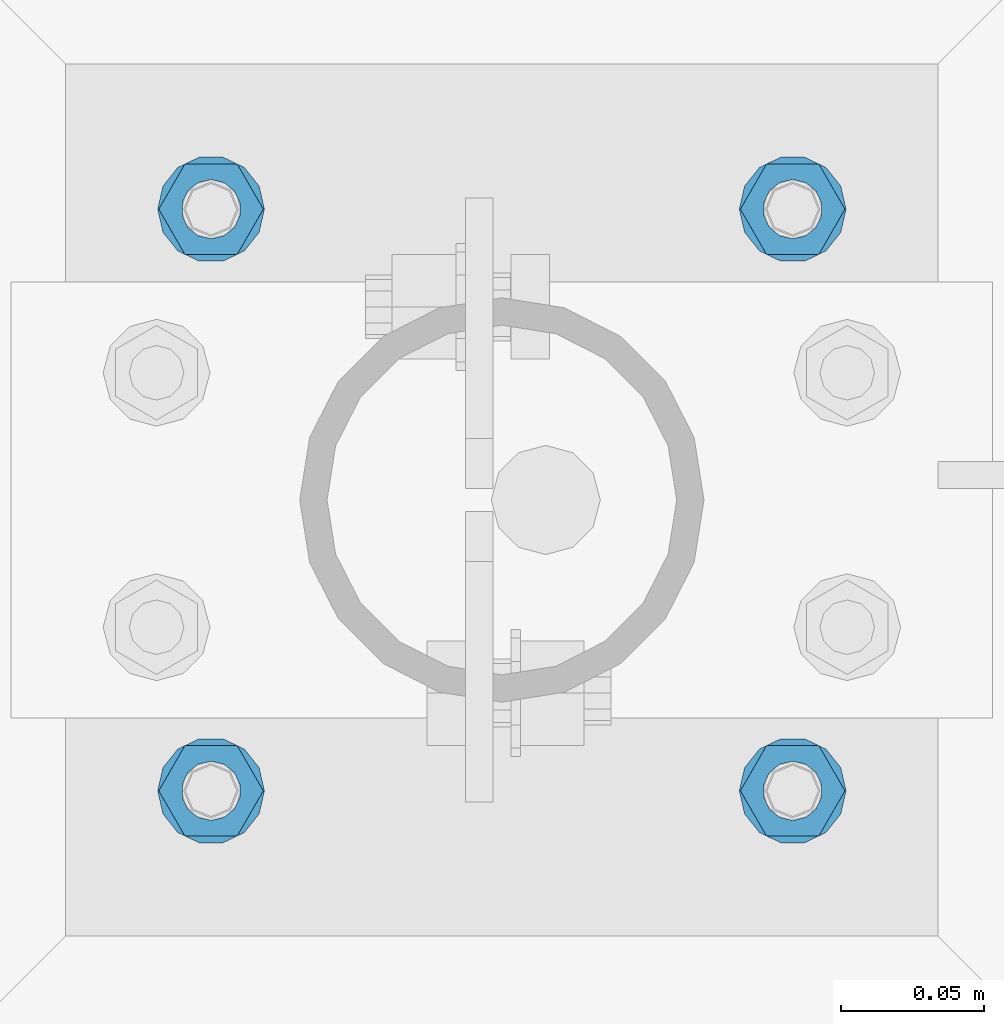
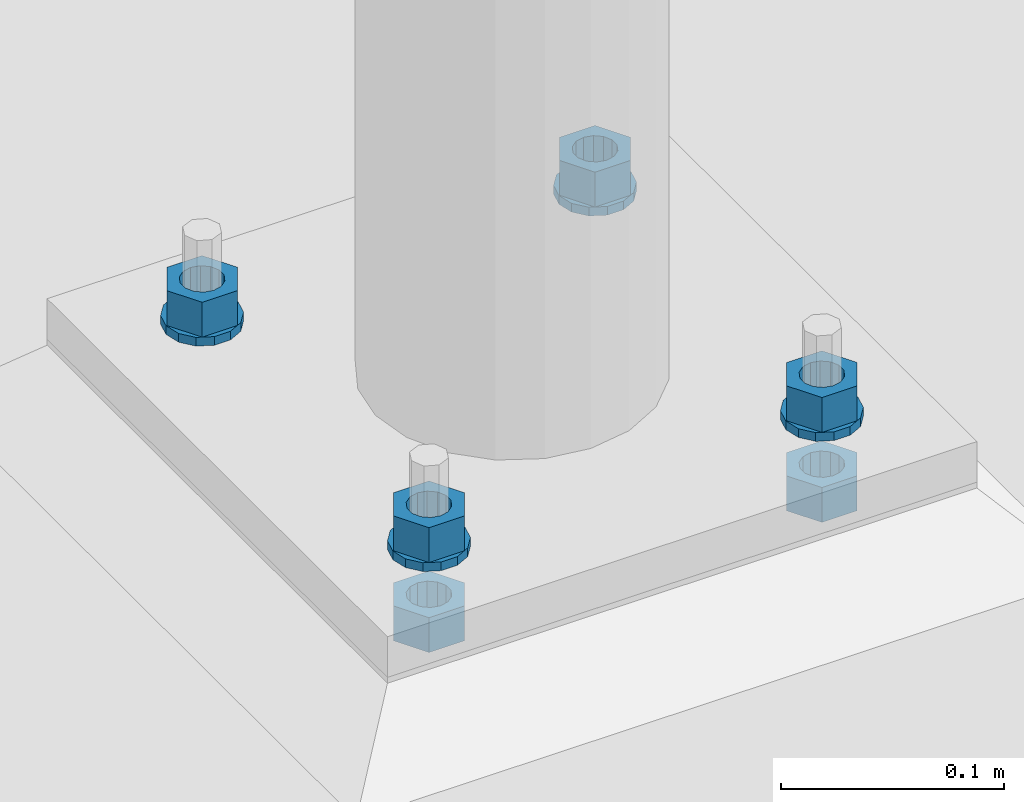
# One storey, part 582 of 975: 10 beams.
"""IFC2X3 building model written with IfcOpenShell, lengths in millimetres."""

from ifc_helpers import new_model, si_unit, frame, origin_with_axes, place, context, subcontext, project, spatial, faceted_brep, material, type_object, element, save


model = new_model("IFC2X3")

# Units and contexts
model_context = context("Model", 3, precision=1e-05, world=origin_with_axes())
body_context = subcontext(model_context, "Body", "Model", "MODEL_VIEW")
ifc_project = project(units=[si_unit("LENGTHUNIT", "METRE", prefix="MILLI"), si_unit("AREAUNIT", "SQUARE_METRE"), si_unit("VOLUMEUNIT", "CUBIC_METRE"), si_unit("MASSUNIT", "GRAM", prefix="KILO"), si_unit("TIMEUNIT", "SECOND"), si_unit("PLANEANGLEUNIT", "RADIAN"), si_unit("SOLIDANGLEUNIT", "STERADIAN"), si_unit("THERMODYNAMICTEMPERATUREUNIT", "DEGREE_CELSIUS"), si_unit("LUMINOUSINTENSITYUNIT", "LUMEN")], contexts=[model_context])

# Site, building, storey
site_placement = place(None, origin_with_axes())
site = spatial("IfcSite", under=ifc_project, at=site_placement, CompositionType="ELEMENT")
building_placement = place(site_placement, origin_with_axes())
building = spatial("IfcBuilding", under=site, at=building_placement, Name="Undefined", CompositionType="ELEMENT")
storey_placement = place(building_placement, origin_with_axes())
storey = spatial("IfcBuildingStorey", under=building, at=storey_placement, Name="Undefined", CompositionType="ELEMENT", Elevation=0.0)

# Beams
ifc_material = material(Name="STEEL/A36")
beam_type_1 = type_object("IfcBeamType", Name="3/4_WASHER", PredefinedType="NOTDEFINED")
beam_1_placement = place(storey_placement, frame((13385.8000015259, 13290.5500030518, -236.537499999998), z_axis=(0.0, -1.0, 0.0), x_axis=(0.0, 0.0, -1.0)))
element("IfcBeam", 1, at=beam_1_placement, inside=storey, type_object=beam_type_1, material=ifc_material, Name="WASHER", ObjectType="3/4_WASHER", context=body_context, shape_type="Brep", body=[
    faceted_brep([(0.0, -18.6499996185303, 0.0), (0.0, -16.8030690426876, -8.09193156902904), (4.76250000000073, -16.8030690426876, -8.09193156902904), (4.76250000000073, -18.6499996185303, 0.0), (0.0, -11.6280845668225, -14.5811568497838), (4.76250000000073, -11.6280845668225, -14.5811568497838), (0.0, -4.15001533340001, -18.1824051902857), (4.76250000000073, -4.15001533340001, -18.1824051902857), (0.0, 4.15001533340001, -18.1824051902857), (4.76250000000073, 4.15001533340001, -18.1824051902857), (0.0, 11.6280845668234, -14.5811568497838), (4.76250000000073, 11.6280845668234, -14.5811568497838), (0.0, 16.8030690426876, -8.09193156902904), (4.76250000000073, 16.8030690426876, -8.09193156902904), (0.0, 18.6499996185303, 0.0), (4.76250000000073, 18.6499996185303, 0.0), (0.0, 16.8030690426876, 8.09193156902904), (4.76250000000073, 16.8030690426876, 8.09193156902904), (0.0, 11.6280845668225, 14.5811568497838), (4.76250000000073, 11.6280845668225, 14.5811568497838), (0.0, 4.15001533340001, 18.1824051902857), (4.76250000000073, 4.15001533340001, 18.1824051902857), (0.0, -4.15001533340001, 18.1824051902857), (4.76250000000073, -4.15001533340001, 18.1824051902857), (0.0, -11.6280845668234, 14.5811568497838), (4.76250000000073, -11.6280845668234, 14.5811568497838), (0.0, -16.8030690426876, 8.09193156902904), (4.76250000000073, -16.8030690426876, 8.09193156902904), (0.0, 0.0, 10.3199996948242), (0.0, 4.47768005528269, 9.29799844179911), (4.76250000000073, 4.47768005528269, 9.29799844179911), (4.76250000000073, 0.0, 10.3199996948242), (0.0, 8.06850066047446, 6.43441456490817), (4.76250000000073, 8.06850066047446, 6.43441456490817), (0.0, 10.0612557561917, 2.29641597052117), (4.76250000000073, 10.0612557561917, 2.29641597052117), (0.0, 10.0612557561917, -2.29641597052117), (4.76250000000073, 10.0612557561917, -2.29641597052117), (0.0, 8.06850066047446, -6.43441456490814), (4.76250000000073, 8.06850066047446, -6.43441456490814), (0.0, 4.47768005528269, -9.29799844179908), (4.76250000000073, 4.47768005528269, -9.29799844179908), (0.0, 0.0, -10.3199996948242), (4.76250000000073, 0.0, -10.3199996948242), (0.0, -4.47768005528269, -9.29799844179911), (4.76250000000073, -4.47768005528269, -9.29799844179911), (0.0, -8.06850066047446, -6.43441456490817), (4.76250000000073, -8.06850066047446, -6.43441456490817), (0.0, -10.0612557561917, -2.29641597052117), (4.76250000000073, -10.0612557561917, -2.29641597052117), (0.0, -10.0612557561917, 2.29641597052117), (4.76250000000073, -10.0612557561917, 2.29641597052117), (0.0, -8.06850066047446, 6.43441456490814), (4.76250000000073, -8.06850066047446, 6.43441456490814), (0.0, -4.47768005528269, 9.29799844179908), (4.76250000000073, -4.47768005528269, 9.29799844179908)], [[[0, 1, 2, 3]], [[1, 4, 5, 2]], [[4, 6, 7, 5]], [[6, 8, 9, 7]], [[8, 10, 11, 9]], [[10, 12, 13, 11]], [[12, 14, 15, 13]], [[14, 16, 17, 15]], [[16, 18, 19, 17]], [[18, 20, 21, 19]], [[20, 22, 23, 21]], [[22, 24, 25, 23]], [[24, 26, 27, 25]], [[26, 0, 3, 27]], [[28, 29, 30, 31]], [[29, 32, 33, 30]], [[32, 34, 35, 33]], [[34, 36, 37, 35]], [[36, 38, 39, 37]], [[38, 40, 41, 39]], [[40, 42, 43, 41]], [[42, 44, 45, 43]], [[44, 46, 47, 45]], [[46, 48, 49, 47]], [[48, 50, 51, 49]], [[50, 52, 53, 51]], [[52, 54, 55, 53]], [[54, 28, 31, 55]], [[5, 7, 9, 11, 13, 15, 17, 19, 21, 23, 25, 27, 3, 2], [33, 35, 37, 39, 41, 43, 45, 47, 49, 51, 53, 55, 31, 30]], [[26, 24, 22, 20, 18, 16, 14, 12, 10, 8, 6, 4, 1, 0], [54, 52, 50, 48, 46, 44, 42, 40, 38, 36, 34, 32, 29, 28]]]),
])
beam_2_placement = place(storey_placement, frame((13588.9999984741, 13290.5500030518, -236.537499999998), z_axis=(0.0, -1.0, 0.0), x_axis=(0.0, 0.0, -1.0)))
element("IfcBeam", 2, at=beam_2_placement, inside=storey, type_object=beam_type_1, material=ifc_material, Name="WASHER", ObjectType="3/4_WASHER", context=body_context, shape_type="Brep", body=[
    faceted_brep([(0.0, -18.6499996185303, 0.0), (0.0, -16.8030690426876, -8.09193156902904), (4.76250000000073, -16.8030690426876, -8.09193156902904), (4.76250000000073, -18.6499996185303, 0.0), (0.0, -11.6280845668225, -14.5811568497838), (4.76250000000073, -11.6280845668225, -14.5811568497838), (0.0, -4.15001533340001, -18.1824051902857), (4.76250000000073, -4.15001533340001, -18.1824051902857), (0.0, 4.15001533340001, -18.1824051902857), (4.76250000000073, 4.15001533340001, -18.1824051902857), (0.0, 11.6280845668234, -14.5811568497838), (4.76250000000073, 11.6280845668234, -14.5811568497838), (0.0, 16.8030690426876, -8.09193156902904), (4.76250000000073, 16.8030690426876, -8.09193156902904), (0.0, 18.6499996185303, 0.0), (4.76250000000073, 18.6499996185303, 0.0), (0.0, 16.8030690426876, 8.09193156902904), (4.76250000000073, 16.8030690426876, 8.09193156902904), (0.0, 11.6280845668225, 14.5811568497838), (4.76250000000073, 11.6280845668225, 14.5811568497838), (0.0, 4.15001533340001, 18.1824051902857), (4.76250000000073, 4.15001533340001, 18.1824051902857), (0.0, -4.15001533340001, 18.1824051902857), (4.76250000000073, -4.15001533340001, 18.1824051902857), (0.0, -11.6280845668234, 14.5811568497838), (4.76250000000073, -11.6280845668234, 14.5811568497838), (0.0, -16.8030690426876, 8.09193156902904), (4.76250000000073, -16.8030690426876, 8.09193156902904), (0.0, 0.0, 10.3199996948242), (0.0, 4.47768005528269, 9.29799844179911), (4.76250000000073, 4.47768005528269, 9.29799844179911), (4.76250000000073, 0.0, 10.3199996948242), (0.0, 8.06850066047446, 6.43441456490817), (4.76250000000073, 8.06850066047446, 6.43441456490817), (0.0, 10.0612557561917, 2.29641597052117), (4.76250000000073, 10.0612557561917, 2.29641597052117), (0.0, 10.0612557561917, -2.29641597052117), (4.76250000000073, 10.0612557561917, -2.29641597052117), (0.0, 8.06850066047446, -6.43441456490814), (4.76250000000073, 8.06850066047446, -6.43441456490814), (0.0, 4.47768005528269, -9.29799844179908), (4.76250000000073, 4.47768005528269, -9.29799844179908), (0.0, 0.0, -10.3199996948242), (4.76250000000073, 0.0, -10.3199996948242), (0.0, -4.47768005528269, -9.29799844179911), (4.76250000000073, -4.47768005528269, -9.29799844179911), (0.0, -8.06850066047446, -6.43441456490817), (4.76250000000073, -8.06850066047446, -6.43441456490817), (0.0, -10.0612557561917, -2.29641597052117), (4.76250000000073, -10.0612557561917, -2.29641597052117), (0.0, -10.0612557561917, 2.29641597052117), (4.76250000000073, -10.0612557561917, 2.29641597052117), (0.0, -8.06850066047446, 6.43441456490814), (4.76250000000073, -8.06850066047446, 6.43441456490814), (0.0, -4.47768005528269, 9.29799844179908), (4.76250000000073, -4.47768005528269, 9.29799844179908)], [[[0, 1, 2, 3]], [[1, 4, 5, 2]], [[4, 6, 7, 5]], [[6, 8, 9, 7]], [[8, 10, 11, 9]], [[10, 12, 13, 11]], [[12, 14, 15, 13]], [[14, 16, 17, 15]], [[16, 18, 19, 17]], [[18, 20, 21, 19]], [[20, 22, 23, 21]], [[22, 24, 25, 23]], [[24, 26, 27, 25]], [[26, 0, 3, 27]], [[28, 29, 30, 31]], [[29, 32, 33, 30]], [[32, 34, 35, 33]], [[34, 36, 37, 35]], [[36, 38, 39, 37]], [[38, 40, 41, 39]], [[40, 42, 43, 41]], [[42, 44, 45, 43]], [[44, 46, 47, 45]], [[46, 48, 49, 47]], [[48, 50, 51, 49]], [[50, 52, 53, 51]], [[52, 54, 55, 53]], [[54, 28, 31, 55]], [[5, 7, 9, 11, 13, 15, 17, 19, 21, 23, 25, 27, 3, 2], [33, 35, 37, 39, 41, 43, 45, 47, 49, 51, 53, 55, 31, 30]], [[26, 24, 22, 20, 18, 16, 14, 12, 10, 8, 6, 4, 1, 0], [54, 52, 50, 48, 46, 44, 42, 40, 38, 36, 34, 32, 29, 28]]]),
])
beam_3_placement = place(storey_placement, frame((13385.8000015259, 13493.75, -236.537499999998), z_axis=(0.0, -1.0, 0.0), x_axis=(0.0, 0.0, -1.0)))
element("IfcBeam", 3, at=beam_3_placement, inside=storey, type_object=beam_type_1, material=ifc_material, Name="WASHER", ObjectType="3/4_WASHER", context=body_context, shape_type="Brep", body=[
    faceted_brep([(0.0, -18.6499996185303, 0.0), (0.0, -16.8030690426876, -8.09193156902904), (4.76250000000073, -16.8030690426876, -8.09193156902904), (4.76250000000073, -18.6499996185303, 0.0), (0.0, -11.6280845668225, -14.5811568497838), (4.76250000000073, -11.6280845668225, -14.5811568497838), (0.0, -4.15001533340001, -18.1824051902857), (4.76250000000073, -4.15001533340001, -18.1824051902857), (0.0, 4.15001533340001, -18.1824051902857), (4.76250000000073, 4.15001533340001, -18.1824051902857), (0.0, 11.6280845668234, -14.5811568497838), (4.76250000000073, 11.6280845668234, -14.5811568497838), (0.0, 16.8030690426876, -8.09193156902904), (4.76250000000073, 16.8030690426876, -8.09193156902904), (0.0, 18.6499996185303, 0.0), (4.76250000000073, 18.6499996185303, 0.0), (0.0, 16.8030690426876, 8.09193156902904), (4.76250000000073, 16.8030690426876, 8.09193156902904), (0.0, 11.6280845668225, 14.5811568497838), (4.76250000000073, 11.6280845668225, 14.5811568497838), (0.0, 4.15001533340001, 18.1824051902857), (4.76250000000073, 4.15001533340001, 18.1824051902857), (0.0, -4.15001533340001, 18.1824051902857), (4.76250000000073, -4.15001533340001, 18.1824051902857), (0.0, -11.6280845668234, 14.5811568497838), (4.76250000000073, -11.6280845668234, 14.5811568497838), (0.0, -16.8030690426876, 8.09193156902904), (4.76250000000073, -16.8030690426876, 8.09193156902904), (0.0, 0.0, 10.3199996948242), (0.0, 4.47768005528269, 9.29799844179911), (4.76250000000073, 4.47768005528269, 9.29799844179911), (4.76250000000073, 0.0, 10.3199996948242), (0.0, 8.06850066047446, 6.43441456490817), (4.76250000000073, 8.06850066047446, 6.43441456490817), (0.0, 10.0612557561917, 2.29641597052117), (4.76250000000073, 10.0612557561917, 2.29641597052117), (0.0, 10.0612557561917, -2.29641597052117), (4.76250000000073, 10.0612557561917, -2.29641597052117), (0.0, 8.06850066047446, -6.43441456490814), (4.76250000000073, 8.06850066047446, -6.43441456490814), (0.0, 4.47768005528269, -9.29799844179908), (4.76250000000073, 4.47768005528269, -9.29799844179908), (0.0, 0.0, -10.3199996948242), (4.76250000000073, 0.0, -10.3199996948242), (0.0, -4.47768005528269, -9.29799844179911), (4.76250000000073, -4.47768005528269, -9.29799844179911), (0.0, -8.06850066047446, -6.43441456490817), (4.76250000000073, -8.06850066047446, -6.43441456490817), (0.0, -10.0612557561917, -2.29641597052117), (4.76250000000073, -10.0612557561917, -2.29641597052117), (0.0, -10.0612557561917, 2.29641597052117), (4.76250000000073, -10.0612557561917, 2.29641597052117), (0.0, -8.06850066047446, 6.43441456490814), (4.76250000000073, -8.06850066047446, 6.43441456490814), (0.0, -4.47768005528269, 9.29799844179908), (4.76250000000073, -4.47768005528269, 9.29799844179908)], [[[0, 1, 2, 3]], [[1, 4, 5, 2]], [[4, 6, 7, 5]], [[6, 8, 9, 7]], [[8, 10, 11, 9]], [[10, 12, 13, 11]], [[12, 14, 15, 13]], [[14, 16, 17, 15]], [[16, 18, 19, 17]], [[18, 20, 21, 19]], [[20, 22, 23, 21]], [[22, 24, 25, 23]], [[24, 26, 27, 25]], [[26, 0, 3, 27]], [[28, 29, 30, 31]], [[29, 32, 33, 30]], [[32, 34, 35, 33]], [[34, 36, 37, 35]], [[36, 38, 39, 37]], [[38, 40, 41, 39]], [[40, 42, 43, 41]], [[42, 44, 45, 43]], [[44, 46, 47, 45]], [[46, 48, 49, 47]], [[48, 50, 51, 49]], [[50, 52, 53, 51]], [[52, 54, 55, 53]], [[54, 28, 31, 55]], [[5, 7, 9, 11, 13, 15, 17, 19, 21, 23, 25, 27, 3, 2], [33, 35, 37, 39, 41, 43, 45, 47, 49, 51, 53, 55, 31, 30]], [[26, 24, 22, 20, 18, 16, 14, 12, 10, 8, 6, 4, 1, 0], [54, 52, 50, 48, 46, 44, 42, 40, 38, 36, 34, 32, 29, 28]]]),
])
beam_4_placement = place(storey_placement, frame((13588.9999984741, 13493.75, -236.537499999998), z_axis=(0.0, -1.0, 0.0), x_axis=(0.0, 0.0, -1.0)))
element("IfcBeam", 4, at=beam_4_placement, inside=storey, type_object=beam_type_1, material=ifc_material, Name="WASHER", ObjectType="3/4_WASHER", context=body_context, shape_type="Brep", body=[
    faceted_brep([(0.0, -18.6499996185303, 0.0), (0.0, -16.8030690426876, -8.09193156902904), (4.76250000000073, -16.8030690426876, -8.09193156902904), (4.76250000000073, -18.6499996185303, 0.0), (0.0, -11.6280845668225, -14.5811568497838), (4.76250000000073, -11.6280845668225, -14.5811568497838), (0.0, -4.15001533340001, -18.1824051902857), (4.76250000000073, -4.15001533340001, -18.1824051902857), (0.0, 4.15001533340001, -18.1824051902857), (4.76250000000073, 4.15001533340001, -18.1824051902857), (0.0, 11.6280845668234, -14.5811568497838), (4.76250000000073, 11.6280845668234, -14.5811568497838), (0.0, 16.8030690426876, -8.09193156902904), (4.76250000000073, 16.8030690426876, -8.09193156902904), (0.0, 18.6499996185303, 0.0), (4.76250000000073, 18.6499996185303, 0.0), (0.0, 16.8030690426876, 8.09193156902904), (4.76250000000073, 16.8030690426876, 8.09193156902904), (0.0, 11.6280845668225, 14.5811568497838), (4.76250000000073, 11.6280845668225, 14.5811568497838), (0.0, 4.15001533340001, 18.1824051902857), (4.76250000000073, 4.15001533340001, 18.1824051902857), (0.0, -4.15001533340001, 18.1824051902857), (4.76250000000073, -4.15001533340001, 18.1824051902857), (0.0, -11.6280845668234, 14.5811568497838), (4.76250000000073, -11.6280845668234, 14.5811568497838), (0.0, -16.8030690426876, 8.09193156902904), (4.76250000000073, -16.8030690426876, 8.09193156902904), (0.0, 0.0, 10.3199996948242), (0.0, 4.47768005528269, 9.29799844179911), (4.76250000000073, 4.47768005528269, 9.29799844179911), (4.76250000000073, 0.0, 10.3199996948242), (0.0, 8.06850066047446, 6.43441456490817), (4.76250000000073, 8.06850066047446, 6.43441456490817), (0.0, 10.0612557561917, 2.29641597052117), (4.76250000000073, 10.0612557561917, 2.29641597052117), (0.0, 10.0612557561917, -2.29641597052117), (4.76250000000073, 10.0612557561917, -2.29641597052117), (0.0, 8.06850066047446, -6.43441456490814), (4.76250000000073, 8.06850066047446, -6.43441456490814), (0.0, 4.47768005528269, -9.29799844179908), (4.76250000000073, 4.47768005528269, -9.29799844179908), (0.0, 0.0, -10.3199996948242), (4.76250000000073, 0.0, -10.3199996948242), (0.0, -4.47768005528269, -9.29799844179911), (4.76250000000073, -4.47768005528269, -9.29799844179911), (0.0, -8.06850066047446, -6.43441456490817), (4.76250000000073, -8.06850066047446, -6.43441456490817), (0.0, -10.0612557561917, -2.29641597052117), (4.76250000000073, -10.0612557561917, -2.29641597052117), (0.0, -10.0612557561917, 2.29641597052117), (4.76250000000073, -10.0612557561917, 2.29641597052117), (0.0, -8.06850066047446, 6.43441456490814), (4.76250000000073, -8.06850066047446, 6.43441456490814), (0.0, -4.47768005528269, 9.29799844179908), (4.76250000000073, -4.47768005528269, 9.29799844179908)], [[[0, 1, 2, 3]], [[1, 4, 5, 2]], [[4, 6, 7, 5]], [[6, 8, 9, 7]], [[8, 10, 11, 9]], [[10, 12, 13, 11]], [[12, 14, 15, 13]], [[14, 16, 17, 15]], [[16, 18, 19, 17]], [[18, 20, 21, 19]], [[20, 22, 23, 21]], [[22, 24, 25, 23]], [[24, 26, 27, 25]], [[26, 0, 3, 27]], [[28, 29, 30, 31]], [[29, 32, 33, 30]], [[32, 34, 35, 33]], [[34, 36, 37, 35]], [[36, 38, 39, 37]], [[38, 40, 41, 39]], [[40, 42, 43, 41]], [[42, 44, 45, 43]], [[44, 46, 47, 45]], [[46, 48, 49, 47]], [[48, 50, 51, 49]], [[50, 52, 53, 51]], [[52, 54, 55, 53]], [[54, 28, 31, 55]], [[5, 7, 9, 11, 13, 15, 17, 19, 21, 23, 25, 27, 3, 2], [33, 35, 37, 39, 41, 43, 45, 47, 49, 51, 53, 55, 31, 30]], [[26, 24, 22, 20, 18, 16, 14, 12, 10, 8, 6, 4, 1, 0], [54, 52, 50, 48, 46, 44, 42, 40, 38, 36, 34, 32, 29, 28]]]),
])
beam_type_2 = type_object("IfcBeamType", Name="3/4_HEAVY_HEX_NUT", PredefinedType="NOTDEFINED")
beam_5_placement = place(storey_placement, frame((13385.8000015259, 13290.5500030518, -217.487499999999), z_axis=(0.0, -1.0, 0.0), x_axis=(0.0, 0.0, -1.0)))
element("IfcBeam", 5, at=beam_5_placement, inside=storey, type_object=beam_type_2, material=ifc_material, Name="NUT", ObjectType="3/4_HEAVY_HEX_NUT", context=body_context, shape_type="Brep", body=[
    faceted_brep([(0.0, -18.2600002288818, 0.0), (0.0, -9.13000011444092, -15.8100004196167), (19.0499999999993, -9.13000011444092, -15.8100004196167), (19.0499999999993, -18.2600002288818, 0.0), (0.0, 9.13000011444092, -15.8100004196167), (19.0499999999993, 9.13000011444092, -15.8100004196167), (0.0, 18.2600002288818, 0.0), (19.0499999999993, 18.2600002288818, 0.0), (0.0, 9.13000011444092, 15.8100004196167), (19.0499999999993, 9.13000011444092, 15.8100004196167), (0.0, -9.13000011444092, 15.8100004196167), (19.0499999999993, -9.13000011444092, 15.8100004196167), (0.0, 0.0, 10.3199996948242), (0.0, 4.47768005528269, 9.29799844179911), (19.0499999999993, 4.47768005528269, 9.29799844179911), (19.0499999999993, 0.0, 10.3199996948242), (0.0, 8.06850066047446, 6.43441456490817), (19.0499999999993, 8.06850066047446, 6.43441456490817), (0.0, 10.0612557561917, 2.29641597052117), (19.0499999999993, 10.0612557561917, 2.29641597052117), (0.0, 10.0612557561917, -2.29641597052117), (19.0499999999993, 10.0612557561917, -2.29641597052117), (0.0, 8.06850066047446, -6.43441456490814), (19.0499999999993, 8.06850066047446, -6.43441456490814), (0.0, 4.47768005528269, -9.29799844179908), (19.0499999999993, 4.47768005528269, -9.29799844179908), (0.0, 0.0, -10.3199996948242), (19.0499999999993, 0.0, -10.3199996948242), (0.0, -4.47768005528269, -9.29799844179911), (19.0499999999993, -4.47768005528269, -9.29799844179911), (0.0, -8.06850066047446, -6.43441456490817), (19.0499999999993, -8.06850066047446, -6.43441456490817), (0.0, -10.0612557561917, -2.29641597052117), (19.0499999999993, -10.0612557561917, -2.29641597052117), (0.0, -10.0612557561917, 2.29641597052117), (19.0499999999993, -10.0612557561917, 2.29641597052117), (0.0, -8.06850066047446, 6.43441456490814), (19.0499999999993, -8.06850066047446, 6.43441456490814), (0.0, -4.47768005528269, 9.29799844179908), (19.0499999999993, -4.47768005528269, 9.29799844179908)], [[[0, 1, 2, 3]], [[1, 4, 5, 2]], [[4, 6, 7, 5]], [[6, 8, 9, 7]], [[8, 10, 11, 9]], [[10, 0, 3, 11]], [[12, 13, 14, 15]], [[13, 16, 17, 14]], [[16, 18, 19, 17]], [[18, 20, 21, 19]], [[20, 22, 23, 21]], [[22, 24, 25, 23]], [[24, 26, 27, 25]], [[26, 28, 29, 27]], [[28, 30, 31, 29]], [[30, 32, 33, 31]], [[32, 34, 35, 33]], [[34, 36, 37, 35]], [[36, 38, 39, 37]], [[38, 12, 15, 39]], [[5, 7, 9, 11, 3, 2], [17, 19, 21, 23, 25, 27, 29, 31, 33, 35, 37, 39, 15, 14]], [[10, 8, 6, 4, 1, 0], [38, 36, 34, 32, 30, 28, 26, 24, 22, 20, 18, 16, 13, 12]]]),
])
beam_6_placement = place(storey_placement, frame((13588.9999984741, 13290.5500030518, -217.487499999999), z_axis=(0.0, -1.0, 0.0), x_axis=(0.0, 0.0, -1.0)))
element("IfcBeam", 6, at=beam_6_placement, inside=storey, type_object=beam_type_2, material=ifc_material, Name="NUT", ObjectType="3/4_HEAVY_HEX_NUT", context=body_context, shape_type="Brep", body=[
    faceted_brep([(0.0, -18.2600002288818, 0.0), (0.0, -9.13000011444092, -15.8100004196167), (19.0499999999993, -9.13000011444092, -15.8100004196167), (19.0499999999993, -18.2600002288818, 0.0), (0.0, 9.13000011444092, -15.8100004196167), (19.0499999999993, 9.13000011444092, -15.8100004196167), (0.0, 18.2600002288818, 0.0), (19.0499999999993, 18.2600002288818, 0.0), (0.0, 9.13000011444092, 15.8100004196167), (19.0499999999993, 9.13000011444092, 15.8100004196167), (0.0, -9.13000011444092, 15.8100004196167), (19.0499999999993, -9.13000011444092, 15.8100004196167), (0.0, 0.0, 10.3199996948242), (0.0, 4.47768005528269, 9.29799844179911), (19.0499999999993, 4.47768005528269, 9.29799844179911), (19.0499999999993, 0.0, 10.3199996948242), (0.0, 8.06850066047446, 6.43441456490817), (19.0499999999993, 8.06850066047446, 6.43441456490817), (0.0, 10.0612557561917, 2.29641597052117), (19.0499999999993, 10.0612557561917, 2.29641597052117), (0.0, 10.0612557561917, -2.29641597052117), (19.0499999999993, 10.0612557561917, -2.29641597052117), (0.0, 8.06850066047446, -6.43441456490814), (19.0499999999993, 8.06850066047446, -6.43441456490814), (0.0, 4.47768005528269, -9.29799844179908), (19.0499999999993, 4.47768005528269, -9.29799844179908), (0.0, 0.0, -10.3199996948242), (19.0499999999993, 0.0, -10.3199996948242), (0.0, -4.47768005528269, -9.29799844179911), (19.0499999999993, -4.47768005528269, -9.29799844179911), (0.0, -8.06850066047446, -6.43441456490817), (19.0499999999993, -8.06850066047446, -6.43441456490817), (0.0, -10.0612557561917, -2.29641597052117), (19.0499999999993, -10.0612557561917, -2.29641597052117), (0.0, -10.0612557561917, 2.29641597052117), (19.0499999999993, -10.0612557561917, 2.29641597052117), (0.0, -8.06850066047446, 6.43441456490814), (19.0499999999993, -8.06850066047446, 6.43441456490814), (0.0, -4.47768005528269, 9.29799844179908), (19.0499999999993, -4.47768005528269, 9.29799844179908)], [[[0, 1, 2, 3]], [[1, 4, 5, 2]], [[4, 6, 7, 5]], [[6, 8, 9, 7]], [[8, 10, 11, 9]], [[10, 0, 3, 11]], [[12, 13, 14, 15]], [[13, 16, 17, 14]], [[16, 18, 19, 17]], [[18, 20, 21, 19]], [[20, 22, 23, 21]], [[22, 24, 25, 23]], [[24, 26, 27, 25]], [[26, 28, 29, 27]], [[28, 30, 31, 29]], [[30, 32, 33, 31]], [[32, 34, 35, 33]], [[34, 36, 37, 35]], [[36, 38, 39, 37]], [[38, 12, 15, 39]], [[5, 7, 9, 11, 3, 2], [17, 19, 21, 23, 25, 27, 29, 31, 33, 35, 37, 39, 15, 14]], [[10, 8, 6, 4, 1, 0], [38, 36, 34, 32, 30, 28, 26, 24, 22, 20, 18, 16, 13, 12]]]),
])
beam_7_placement = place(storey_placement, frame((13385.8000015259, 13493.75, -217.487499999999), z_axis=(0.0, -1.0, 0.0), x_axis=(0.0, 0.0, -1.0)))
element("IfcBeam", 7, at=beam_7_placement, inside=storey, type_object=beam_type_2, material=ifc_material, Name="NUT", ObjectType="3/4_HEAVY_HEX_NUT", context=body_context, shape_type="Brep", body=[
    faceted_brep([(0.0, -18.2600002288818, 0.0), (0.0, -9.13000011444092, -15.8100004196167), (19.0499999999993, -9.13000011444092, -15.8100004196167), (19.0499999999993, -18.2600002288818, 0.0), (0.0, 9.13000011444092, -15.8100004196167), (19.0499999999993, 9.13000011444092, -15.8100004196167), (0.0, 18.2600002288818, 0.0), (19.0499999999993, 18.2600002288818, 0.0), (0.0, 9.13000011444092, 15.8100004196167), (19.0499999999993, 9.13000011444092, 15.8100004196167), (0.0, -9.13000011444092, 15.8100004196167), (19.0499999999993, -9.13000011444092, 15.8100004196167), (0.0, 0.0, 10.3199996948242), (0.0, 4.47768005528269, 9.29799844179911), (19.0499999999993, 4.47768005528269, 9.29799844179911), (19.0499999999993, 0.0, 10.3199996948242), (0.0, 8.06850066047446, 6.43441456490817), (19.0499999999993, 8.06850066047446, 6.43441456490817), (0.0, 10.0612557561917, 2.29641597052117), (19.0499999999993, 10.0612557561917, 2.29641597052117), (0.0, 10.0612557561917, -2.29641597052117), (19.0499999999993, 10.0612557561917, -2.29641597052117), (0.0, 8.06850066047446, -6.43441456490814), (19.0499999999993, 8.06850066047446, -6.43441456490814), (0.0, 4.47768005528269, -9.29799844179908), (19.0499999999993, 4.47768005528269, -9.29799844179908), (0.0, 0.0, -10.3199996948242), (19.0499999999993, 0.0, -10.3199996948242), (0.0, -4.47768005528269, -9.29799844179911), (19.0499999999993, -4.47768005528269, -9.29799844179911), (0.0, -8.06850066047446, -6.43441456490817), (19.0499999999993, -8.06850066047446, -6.43441456490817), (0.0, -10.0612557561917, -2.29641597052117), (19.0499999999993, -10.0612557561917, -2.29641597052117), (0.0, -10.0612557561917, 2.29641597052117), (19.0499999999993, -10.0612557561917, 2.29641597052117), (0.0, -8.06850066047446, 6.43441456490814), (19.0499999999993, -8.06850066047446, 6.43441456490814), (0.0, -4.47768005528269, 9.29799844179908), (19.0499999999993, -4.47768005528269, 9.29799844179908)], [[[0, 1, 2, 3]], [[1, 4, 5, 2]], [[4, 6, 7, 5]], [[6, 8, 9, 7]], [[8, 10, 11, 9]], [[10, 0, 3, 11]], [[12, 13, 14, 15]], [[13, 16, 17, 14]], [[16, 18, 19, 17]], [[18, 20, 21, 19]], [[20, 22, 23, 21]], [[22, 24, 25, 23]], [[24, 26, 27, 25]], [[26, 28, 29, 27]], [[28, 30, 31, 29]], [[30, 32, 33, 31]], [[32, 34, 35, 33]], [[34, 36, 37, 35]], [[36, 38, 39, 37]], [[38, 12, 15, 39]], [[5, 7, 9, 11, 3, 2], [17, 19, 21, 23, 25, 27, 29, 31, 33, 35, 37, 39, 15, 14]], [[10, 8, 6, 4, 1, 0], [38, 36, 34, 32, 30, 28, 26, 24, 22, 20, 18, 16, 13, 12]]]),
])
beam_8_placement = place(storey_placement, frame((13588.9999984741, 13493.75, -217.487499999999), z_axis=(0.0, -1.0, 0.0), x_axis=(0.0, 0.0, -1.0)))
element("IfcBeam", 8, at=beam_8_placement, inside=storey, type_object=beam_type_2, material=ifc_material, Name="NUT", ObjectType="3/4_HEAVY_HEX_NUT", context=body_context, shape_type="Brep", body=[
    faceted_brep([(0.0, -18.2600002288818, 0.0), (0.0, -9.13000011444092, -15.8100004196167), (19.0499999999993, -9.13000011444092, -15.8100004196167), (19.0499999999993, -18.2600002288818, 0.0), (0.0, 9.13000011444092, -15.8100004196167), (19.0499999999993, 9.13000011444092, -15.8100004196167), (0.0, 18.2600002288818, 0.0), (19.0499999999993, 18.2600002288818, 0.0), (0.0, 9.13000011444092, 15.8100004196167), (19.0499999999993, 9.13000011444092, 15.8100004196167), (0.0, -9.13000011444092, 15.8100004196167), (19.0499999999993, -9.13000011444092, 15.8100004196167), (0.0, 0.0, 10.3199996948242), (0.0, 4.47768005528269, 9.29799844179911), (19.0499999999993, 4.47768005528269, 9.29799844179911), (19.0499999999993, 0.0, 10.3199996948242), (0.0, 8.06850066047446, 6.43441456490817), (19.0499999999993, 8.06850066047446, 6.43441456490817), (0.0, 10.0612557561917, 2.29641597052117), (19.0499999999993, 10.0612557561917, 2.29641597052117), (0.0, 10.0612557561917, -2.29641597052117), (19.0499999999993, 10.0612557561917, -2.29641597052117), (0.0, 8.06850066047446, -6.43441456490814), (19.0499999999993, 8.06850066047446, -6.43441456490814), (0.0, 4.47768005528269, -9.29799844179908), (19.0499999999993, 4.47768005528269, -9.29799844179908), (0.0, 0.0, -10.3199996948242), (19.0499999999993, 0.0, -10.3199996948242), (0.0, -4.47768005528269, -9.29799844179911), (19.0499999999993, -4.47768005528269, -9.29799844179911), (0.0, -8.06850066047446, -6.43441456490817), (19.0499999999993, -8.06850066047446, -6.43441456490817), (0.0, -10.0612557561917, -2.29641597052117), (19.0499999999993, -10.0612557561917, -2.29641597052117), (0.0, -10.0612557561917, 2.29641597052117), (19.0499999999993, -10.0612557561917, 2.29641597052117), (0.0, -8.06850066047446, 6.43441456490814), (19.0499999999993, -8.06850066047446, 6.43441456490814), (0.0, -4.47768005528269, 9.29799844179908), (19.0499999999993, -4.47768005528269, 9.29799844179908)], [[[0, 1, 2, 3]], [[1, 4, 5, 2]], [[4, 6, 7, 5]], [[6, 8, 9, 7]], [[8, 10, 11, 9]], [[10, 0, 3, 11]], [[12, 13, 14, 15]], [[13, 16, 17, 14]], [[16, 18, 19, 17]], [[18, 20, 21, 19]], [[20, 22, 23, 21]], [[22, 24, 25, 23]], [[24, 26, 27, 25]], [[26, 28, 29, 27]], [[28, 30, 31, 29]], [[30, 32, 33, 31]], [[32, 34, 35, 33]], [[34, 36, 37, 35]], [[36, 38, 39, 37]], [[38, 12, 15, 39]], [[5, 7, 9, 11, 3, 2], [17, 19, 21, 23, 25, 27, 29, 31, 33, 35, 37, 39, 15, 14]], [[10, 8, 6, 4, 1, 0], [38, 36, 34, 32, 30, 28, 26, 24, 22, 20, 18, 16, 13, 12]]]),
])
beam_9_placement = place(storey_placement, frame((13385.8000015259, 13290.5500030518, -266.7), z_axis=(0.0, -1.0, 0.0), x_axis=(0.0, 0.0, -1.0)))
element("IfcBeam", 9, at=beam_9_placement, inside=storey, type_object=beam_type_2, material=ifc_material, Name="NUT", ObjectType="3/4_HEAVY_HEX_NUT", context=body_context, shape_type="Brep", body=[
    faceted_brep([(0.0, -18.2600002288818, 0.0), (0.0, -9.13000011444092, -15.8100004196167), (19.0499999999993, -9.13000011444092, -15.8100004196167), (19.0499999999993, -18.2600002288818, 0.0), (0.0, 9.13000011444092, -15.8100004196167), (19.0499999999993, 9.13000011444092, -15.8100004196167), (0.0, 18.2600002288818, 0.0), (19.0499999999993, 18.2600002288818, 0.0), (0.0, 9.13000011444092, 15.8100004196167), (19.0499999999993, 9.13000011444092, 15.8100004196167), (0.0, -9.13000011444092, 15.8100004196167), (19.0499999999993, -9.13000011444092, 15.8100004196167), (0.0, 0.0, 10.3199996948242), (0.0, 4.47768005528269, 9.29799844179911), (19.0499999999993, 4.47768005528269, 9.29799844179911), (19.0499999999993, 0.0, 10.3199996948242), (0.0, 8.06850066047446, 6.43441456490817), (19.0499999999993, 8.06850066047446, 6.43441456490817), (0.0, 10.0612557561917, 2.29641597052117), (19.0499999999993, 10.0612557561917, 2.29641597052117), (0.0, 10.0612557561917, -2.29641597052117), (19.0499999999993, 10.0612557561917, -2.29641597052117), (0.0, 8.06850066047446, -6.43441456490814), (19.0499999999993, 8.06850066047446, -6.43441456490814), (0.0, 4.47768005528269, -9.29799844179908), (19.0499999999993, 4.47768005528269, -9.29799844179908), (0.0, 0.0, -10.3199996948242), (19.0499999999993, 0.0, -10.3199996948242), (0.0, -4.47768005528269, -9.29799844179911), (19.0499999999993, -4.47768005528269, -9.29799844179911), (0.0, -8.06850066047446, -6.43441456490817), (19.0499999999993, -8.06850066047446, -6.43441456490817), (0.0, -10.0612557561917, -2.29641597052117), (19.0499999999993, -10.0612557561917, -2.29641597052117), (0.0, -10.0612557561917, 2.29641597052117), (19.0499999999993, -10.0612557561917, 2.29641597052117), (0.0, -8.06850066047446, 6.43441456490814), (19.0499999999993, -8.06850066047446, 6.43441456490814), (0.0, -4.47768005528269, 9.29799844179908), (19.0499999999993, -4.47768005528269, 9.29799844179908)], [[[0, 1, 2, 3]], [[1, 4, 5, 2]], [[4, 6, 7, 5]], [[6, 8, 9, 7]], [[8, 10, 11, 9]], [[10, 0, 3, 11]], [[12, 13, 14, 15]], [[13, 16, 17, 14]], [[16, 18, 19, 17]], [[18, 20, 21, 19]], [[20, 22, 23, 21]], [[22, 24, 25, 23]], [[24, 26, 27, 25]], [[26, 28, 29, 27]], [[28, 30, 31, 29]], [[30, 32, 33, 31]], [[32, 34, 35, 33]], [[34, 36, 37, 35]], [[36, 38, 39, 37]], [[38, 12, 15, 39]], [[5, 7, 9, 11, 3, 2], [17, 19, 21, 23, 25, 27, 29, 31, 33, 35, 37, 39, 15, 14]], [[10, 8, 6, 4, 1, 0], [38, 36, 34, 32, 30, 28, 26, 24, 22, 20, 18, 16, 13, 12]]]),
])
beam_10_placement = place(storey_placement, frame((13588.9999984741, 13290.5500030518, -266.7), z_axis=(0.0, -1.0, 0.0), x_axis=(0.0, 0.0, -1.0)))
element("IfcBeam", 10, at=beam_10_placement, inside=storey, type_object=beam_type_2, material=ifc_material, Name="NUT", ObjectType="3/4_HEAVY_HEX_NUT", context=body_context, shape_type="Brep", body=[
    faceted_brep([(0.0, -18.2600002288818, 0.0), (0.0, -9.13000011444092, -15.8100004196167), (19.0499999999993, -9.13000011444092, -15.8100004196167), (19.0499999999993, -18.2600002288818, 0.0), (0.0, 9.13000011444092, -15.8100004196167), (19.0499999999993, 9.13000011444092, -15.8100004196167), (0.0, 18.2600002288818, 0.0), (19.0499999999993, 18.2600002288818, 0.0), (0.0, 9.13000011444092, 15.8100004196167), (19.0499999999993, 9.13000011444092, 15.8100004196167), (0.0, -9.13000011444092, 15.8100004196167), (19.0499999999993, -9.13000011444092, 15.8100004196167), (0.0, 0.0, 10.3199996948242), (0.0, 4.47768005528269, 9.29799844179911), (19.0499999999993, 4.47768005528269, 9.29799844179911), (19.0499999999993, 0.0, 10.3199996948242), (0.0, 8.06850066047446, 6.43441456490817), (19.0499999999993, 8.06850066047446, 6.43441456490817), (0.0, 10.0612557561917, 2.29641597052117), (19.0499999999993, 10.0612557561917, 2.29641597052117), (0.0, 10.0612557561917, -2.29641597052117), (19.0499999999993, 10.0612557561917, -2.29641597052117), (0.0, 8.06850066047446, -6.43441456490814), (19.0499999999993, 8.06850066047446, -6.43441456490814), (0.0, 4.47768005528269, -9.29799844179908), (19.0499999999993, 4.47768005528269, -9.29799844179908), (0.0, 0.0, -10.3199996948242), (19.0499999999993, 0.0, -10.3199996948242), (0.0, -4.47768005528269, -9.29799844179911), (19.0499999999993, -4.47768005528269, -9.29799844179911), (0.0, -8.06850066047446, -6.43441456490817), (19.0499999999993, -8.06850066047446, -6.43441456490817), (0.0, -10.0612557561917, -2.29641597052117), (19.0499999999993, -10.0612557561917, -2.29641597052117), (0.0, -10.0612557561917, 2.29641597052117), (19.0499999999993, -10.0612557561917, 2.29641597052117), (0.0, -8.06850066047446, 6.43441456490814), (19.0499999999993, -8.06850066047446, 6.43441456490814), (0.0, -4.47768005528269, 9.29799844179908), (19.0499999999993, -4.47768005528269, 9.29799844179908)], [[[0, 1, 2, 3]], [[1, 4, 5, 2]], [[4, 6, 7, 5]], [[6, 8, 9, 7]], [[8, 10, 11, 9]], [[10, 0, 3, 11]], [[12, 13, 14, 15]], [[13, 16, 17, 14]], [[16, 18, 19, 17]], [[18, 20, 21, 19]], [[20, 22, 23, 21]], [[22, 24, 25, 23]], [[24, 26, 27, 25]], [[26, 28, 29, 27]], [[28, 30, 31, 29]], [[30, 32, 33, 31]], [[32, 34, 35, 33]], [[34, 36, 37, 35]], [[36, 38, 39, 37]], [[38, 12, 15, 39]], [[5, 7, 9, 11, 3, 2], [17, 19, 21, 23, 25, 27, 29, 31, 33, 35, 37, 39, 15, 14]], [[10, 8, 6, 4, 1, 0], [38, 36, 34, 32, 30, 28, 26, 24, 22, 20, 18, 16, 13, 12]]]),
])

save(model, "model.ifc")
